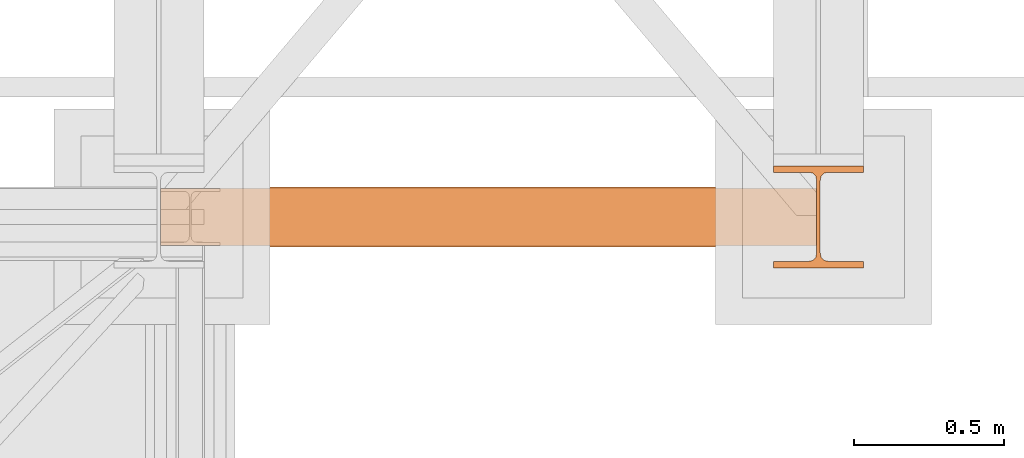
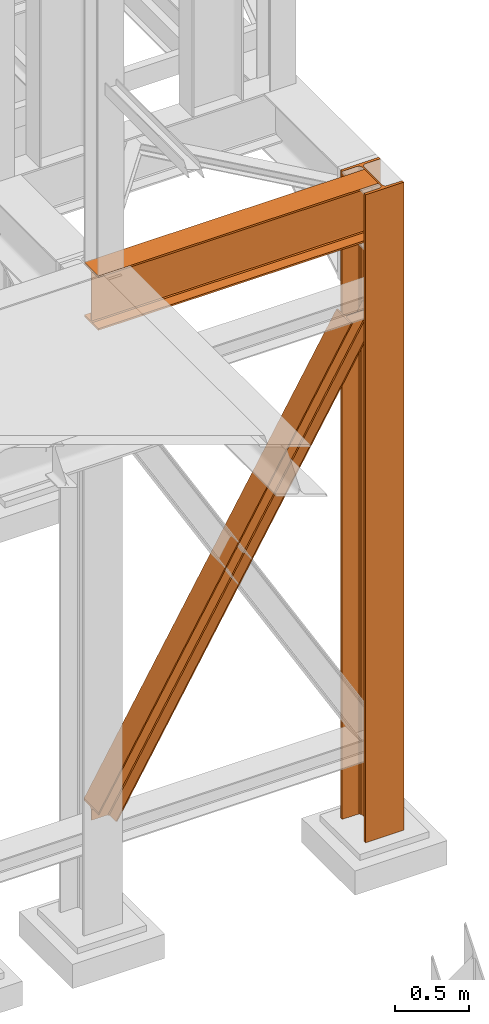
# One storey, part 81 of 208: 3 proxies.
"""IFC2X3 building model written with IfcOpenShell, lengths in millimetres."""

from ifc_helpers import new_model, entity, si_unit, converted_unit, frame, origin, origin_with_axes, place, context, subcontext, project, spatial, faceted_brep, material, element, save


model = new_model("IFC2X3")

# Units and contexts
model_context = context("Model", 3, precision=1e-05, world=origin())
plan_context = context("Plan", 3, precision=1e-05, world=origin())
body_context = subcontext(model_context, "Body", "Model", "MODEL_VIEW")
ifc_project = project(units=[si_unit("LENGTHUNIT", "METRE", prefix="MILLI"), converted_unit("PLANEANGLEUNIT", "DEGREE", entity("IfcPlaneAngleMeasure", 0.0174532925199433), si_unit("PLANEANGLEUNIT", "RADIAN"), dimensions=[0, 0, 0, 0, 0, 0, 0]), si_unit("AREAUNIT", "SQUARE_METRE"), si_unit("VOLUMEUNIT", "CUBIC_METRE")], contexts=[model_context, plan_context])

# Building, storey
building_placement = place(None, origin())
building = spatial("IfcBuilding", under=ifc_project, at=building_placement, CompositionType="COMPLEX")
storey_placement = place(building_placement, origin_with_axes())
storey = spatial("IfcBuildingStorey", under=building, at=storey_placement, Name="Geschoss", CompositionType="ELEMENT")

# Proxies
ifc_material = material(Name="35/80cm")
proxy_1_placement = place(storey_placement, frame((8643.254962568202, -17432.57439531565, -65.01000000000022), z_axis=(0.0, 0.0, 1.0), x_axis=(1.0, 0.0, 0.0)))
element("IfcBuildingElementProxy", 1, at=proxy_1_placement, inside=storey, material=ifc_material, context=body_context, shape_type="Brep", body=[
    faceted_brep([(300.0100119209292, 0.00999999999839929, 0.01000000000027512), (300.0100119209292, 21.51000631809075, 0.01000000000027512), (183.0100057816508, 21.51000631809075, 0.01000000000027512), (169.036290997863, 24.30682016372521, 0.01000000000027512), (158.8068282401564, 34.5362885093673, 0.01000000000027512), (156.0100060126188, 48.51000143050987, 0.01000000000027512), (156.0100060126188, 291.509994695185, 0.01000000000027512), (158.8068282401564, 305.4837150669082, 0.01000000000027512), (169.036290997863, 315.7131685113891, 0.01000000000027512), (183.0100057816508, 318.5099972581847, 0.01000000000027512), (300.0100119209292, 318.5099972581847, 0.01000000000027512), (300.0100119209292, 340.0100035762771, 0.01000000000027512), (0.01000000000021828, 340.0100035762771, 0.01000000000027512), (0.01000000000021828, 318.5099972581847, 0.01000000000027512), (117.0100061392786, 318.5099972581847, 0.01000000000027512), (130.9837209230664, 315.7131685113891, 0.01000000000027512), (141.213183680773, 305.4837150669082, 0.01000000000027512), (144.0100059083106, 291.509994695185, 0.01000000000027512), (144.0100059083106, 48.51000143050987, 0.01000000000027512), (141.213183680773, 34.5362885093673, 0.01000000000027512), (130.9837209230664, 24.30682016372521, 0.01000000000027512), (117.0100061392786, 21.51000631809075, 0.01000000000027512), (0.01000000000021828, 21.51000631809075, 0.01000000000027512), (0.01000000000021828, 0.00999999999839929, 0.01000000000027512), (300.0100119209292, 21.51000631809075, 5350.010005364416), (300.0100119209292, 0.00999999999839929, 5350.010005364416), (0.01000000000021828, 0.00999999999839929, 5350.010005364416), (0.01000000000021828, 21.51000631809075, 5350.010005364416), (117.0100061392786, 21.51000631809075, 5350.010005364416), (130.9837209230664, 24.30682016372521, 5350.010005364416), (141.213183680773, 34.5362885093673, 5350.010005364416), (144.0100059083106, 48.51000143050987, 5350.010005364416), (144.0100059083106, 291.509994695185, 5350.010005364416), (141.213183680773, 305.4837150669082, 5350.010005364416), (130.9837209230664, 315.7131685113891, 5350.010005364416), (117.0100061392786, 318.5099972581847, 5350.010005364416), (0.01000000000021828, 318.5099972581847, 5350.010005364416), (0.01000000000021828, 340.0100035762771, 5350.010005364416), (300.0100119209292, 340.0100035762771, 5350.010005364416), (300.0100119209292, 318.5099972581847, 5350.010005364416), (183.0100057816508, 318.5099972581847, 5350.010005364416), (169.036290997863, 315.7131685113891, 5350.010005364416), (158.8068282401564, 305.4837150669082, 5350.010005364416), (156.0100060126188, 291.509994695185, 5350.010005364416), (156.0100060126188, 48.51000143050987, 5350.010005364416), (158.8068282401564, 34.5362885093673, 5350.010005364416), (169.036290997863, 24.30682016372521, 5350.010005364416), (183.0100057816508, 21.51000631809075, 5350.010005364416), (300.0100119209292, 21.51000631809075, 0.01000000000027512), (300.0100119209292, 0.00999999999839929, 0.01000000000027512), (300.0100119209292, 0.00999999999839929, 5350.010005364416), (300.0100119209292, 21.51000631809075, 5350.010005364416), (183.0100057816508, 21.51000631809075, 0.01000000000027512), (300.0100119209292, 21.51000631809075, 0.01000000000027512), (300.0100119209292, 21.51000631809075, 5350.010005364416), (183.0100057816508, 21.51000631809075, 5350.010005364416), (169.036290997863, 24.30682016372521, 0.01000000000027512), (183.0100057816508, 21.51000631809075, 0.01000000000027512), (183.0100057816508, 21.51000631809075, 5350.010005364416), (169.036290997863, 24.30682016372521, 5350.010005364416), (158.8068282401564, 34.5362885093673, 0.01000000000027512), (169.036290997863, 24.30682016372521, 0.01000000000027512), (169.036290997863, 24.30682016372521, 5350.010005364416), (158.8068282401564, 34.5362885093673, 5350.010005364416), (156.0100060126188, 48.51000143050987, 0.01000000000027512), (158.8068282401564, 34.5362885093673, 0.01000000000027512), (158.8068282401564, 34.5362885093673, 5350.010005364416), (156.0100060126188, 48.51000143050987, 5350.010005364416), (156.0100060126188, 291.509994695185, 0.01000000000027512), (156.0100060126188, 48.51000143050987, 0.01000000000027512), (156.0100060126188, 48.51000143050987, 5350.010005364416), (156.0100060126188, 291.509994695185, 5350.010005364416), (158.8068282401564, 305.4837150669082, 0.01000000000027512), (156.0100060126188, 291.509994695185, 0.01000000000027512), (156.0100060126188, 291.509994695185, 5350.010005364416), (158.8068282401564, 305.4837150669082, 5350.010005364416), (169.036290997863, 315.7131685113891, 0.01000000000027512), (158.8068282401564, 305.4837150669082, 0.01000000000027512), (158.8068282401564, 305.4837150669082, 5350.010005364416), (169.036290997863, 315.7131685113891, 5350.010005364416), (183.0100057816508, 318.5099972581847, 0.01000000000027512), (169.036290997863, 315.7131685113891, 0.01000000000027512), (169.036290997863, 315.7131685113891, 5350.010005364416), (183.0100057816508, 318.5099972581847, 5350.010005364416), (300.0100119209292, 318.5099972581847, 0.01000000000027512), (183.0100057816508, 318.5099972581847, 0.01000000000027512), (183.0100057816508, 318.5099972581847, 5350.010005364416), (300.0100119209292, 318.5099972581847, 5350.010005364416), (300.0100119209292, 340.0100035762771, 0.01000000000027512), (300.0100119209292, 318.5099972581847, 0.01000000000027512), (300.0100119209292, 318.5099972581847, 5350.010005364416), (300.0100119209292, 340.0100035762771, 5350.010005364416), (0.01000000000021828, 340.0100035762771, 0.01000000000027512), (300.0100119209292, 340.0100035762771, 0.01000000000027512), (300.0100119209292, 340.0100035762771, 5350.010005364416), (0.01000000000021828, 340.0100035762771, 5350.010005364416), (0.01000000000021828, 318.5099972581847, 0.01000000000027512), (0.01000000000021828, 340.0100035762771, 0.01000000000027512), (0.01000000000021828, 340.0100035762771, 5350.010005364416), (0.01000000000021828, 318.5099972581847, 5350.010005364416), (117.0100061392786, 318.5099972581847, 0.01000000000027512), (0.01000000000021828, 318.5099972581847, 0.01000000000027512), (0.01000000000021828, 318.5099972581847, 5350.010005364416), (117.0100061392786, 318.5099972581847, 5350.010005364416), (130.9837209230664, 315.7131685113891, 0.01000000000027512), (117.0100061392786, 318.5099972581847, 0.01000000000027512), (117.0100061392786, 318.5099972581847, 5350.010005364416), (130.9837209230664, 315.7131685113891, 5350.010005364416), (141.213183680773, 305.4837150669082, 0.01000000000027512), (130.9837209230664, 315.7131685113891, 0.01000000000027512), (130.9837209230664, 315.7131685113891, 5350.010005364416), (141.213183680773, 305.4837150669082, 5350.010005364416), (144.0100059083106, 291.509994695185, 0.01000000000027512), (141.213183680773, 305.4837150669082, 0.01000000000027512), (141.213183680773, 305.4837150669082, 5350.010005364416), (144.0100059083106, 291.509994695185, 5350.010005364416), (144.0100059083106, 48.51000143050987, 0.01000000000027512), (144.0100059083106, 291.509994695185, 0.01000000000027512), (144.0100059083106, 291.509994695185, 5350.010005364416), (144.0100059083106, 48.51000143050987, 5350.010005364416), (141.213183680773, 34.5362885093673, 0.01000000000027512), (144.0100059083106, 48.51000143050987, 0.01000000000027512), (144.0100059083106, 48.51000143050987, 5350.010005364416), (141.213183680773, 34.5362885093673, 5350.010005364416), (130.9837209230664, 24.30682016372521, 0.01000000000027512), (141.213183680773, 34.5362885093673, 0.01000000000027512), (141.213183680773, 34.5362885093673, 5350.010005364416), (130.9837209230664, 24.30682016372521, 5350.010005364416), (117.0100061392786, 21.51000631809075, 0.01000000000027512), (130.9837209230664, 24.30682016372521, 0.01000000000027512), (130.9837209230664, 24.30682016372521, 5350.010005364416), (117.0100061392786, 21.51000631809075, 5350.010005364416), (0.01000000000021828, 21.51000631809075, 0.01000000000027512), (117.0100061392786, 21.51000631809075, 0.01000000000027512), (117.0100061392786, 21.51000631809075, 5350.010005364416), (0.01000000000021828, 21.51000631809075, 5350.010005364416), (0.01000000000021828, 0.00999999999839929, 0.01000000000027512), (0.01000000000021828, 21.51000631809075, 0.01000000000027512), (0.01000000000021828, 21.51000631809075, 5350.010005364416), (0.01000000000021828, 0.00999999999839929, 5350.010005364416), (300.0100119209292, 0.00999999999839929, 0.01000000000027512), (0.01000000000021828, 0.00999999999839929, 0.01000000000027512), (0.01000000000021828, 0.00999999999839929, 5350.010005364416), (300.0100119209292, 0.00999999999839929, 5350.010005364416)], [[[0, 1, 2, 3, 4, 5, 6, 7, 8, 9, 10, 11, 12, 13, 14, 15, 16, 17, 18, 19, 20, 21, 22, 23]], [[24, 25, 26, 27, 28, 29, 30, 31, 32, 33, 34, 35, 36, 37, 38, 39, 40, 41, 42, 43, 44, 45, 46, 47]], [[48, 49, 50, 51]], [[52, 53, 54, 55]], [[56, 57, 58, 59]], [[60, 61, 62, 63]], [[64, 65, 66, 67]], [[68, 69, 70, 71]], [[72, 73, 74, 75]], [[76, 77, 78, 79]], [[80, 81, 82, 83]], [[84, 85, 86, 87]], [[88, 89, 90, 91]], [[92, 93, 94, 95]], [[96, 97, 98, 99]], [[100, 101, 102, 103]], [[104, 105, 106, 107]], [[108, 109, 110, 111]], [[112, 113, 114, 115]], [[116, 117, 118, 119]], [[120, 121, 122, 123]], [[124, 125, 126, 127]], [[128, 129, 130, 131]], [[132, 133, 134, 135]], [[136, 137, 138, 139]], [[140, 141, 142, 143]]], orient=[[False], [False], [False], [False], [False], [False], [False], [False], [False], [False], [False], [False], [False], [False], [False], [False], [False], [False], [False], [False], [False], [False], [False], [False], [False], [False]]),
])
proxy_2_placement = place(storey_placement, frame((6600.004889571828, -17362.5323246858, 734.9900149335328), z_axis=(0.0, 0.0, 1.0), x_axis=(1.0, 0.0, 0.0)))
element("IfcBuildingElementProxy", 2, at=proxy_2_placement, inside=storey, context=body_context, shape_type="Brep", body=[
    faceted_brep([(0.01008502161312208, 0.00999999999839929, 120.8497915510925), (0.01008502161312208, 200.0100029802306, 120.8497915510925), (1970.595410063093, 200.0100029802306, 3468.009977913908), (1970.595410063093, 0.00999999999839929, 3468.009977913908), (0.01008502161312208, 200.0100029802306, 120.8497915510925), (0.01008502161312208, 200.0100029802306, 101.4682129393399), (1982.007890767009, 200.0100029802306, 3468.009977913908), (1970.595410063093, 200.0100029802306, 3468.009977913908), (0.01008502161312208, 200.0100029802306, 101.4682129393399), (0.01008502127388056, 121.2600035762771, 101.4681984983712), (1982.007899269971, 121.2600035762771, 3468.009977913908), (1982.007890767009, 200.0100029802306, 3468.009977913908), (0.01008502127388056, 121.2600035762771, 101.4681984983712), (0.009999999999308784, 111.9441915473326, 97.8542740943027), (1984.135808151257, 111.9441915473326, 3468.009977913909), (1982.007899269971, 121.2600035762771, 3468.009977913908), (0.009999999999308784, 111.9441915473326, 97.8542740943027), (0.01008502161312208, 105.1245498640819, 84.63689245399053), (1991.918714280975, 105.1245498640819, 3468.009977913908), (1984.135808151257, 111.9441915473326, 3468.009977913909), (0.01008502161312208, 105.1245498640819, 84.63689245399053), (0.01008502161312208, 103.2600015571697, 66.58142866151934), (2002.550367938204, 103.2600015571697, 3468.009977913908), (1991.918714280975, 105.1245498640819, 3468.009977913908), (0.01008502161312208, 103.2600015571697, 0.01000000000010459), (113.7187158034394, 103.2600015571697, 0.01000000000033197), (2155.477653586077, 103.2600015571697, 3468.009977913908), (2002.550367938204, 103.2600015571697, 3468.009977913908), (0.01008502161312208, 103.2600015571697, 66.58142866151934), (113.7187158034394, 103.2600015571697, 0.01000000000033197), (124.3486060538462, 105.1245498640819, 0.01000000000021828), (2166.109307243305, 105.1245498640819, 3468.009977913908), (2155.477653586077, 103.2600015571697, 3468.009977913908), (124.3486060538462, 105.1245498640819, 0.01000000000021828), (132.1302232850376, 111.9441915473326, 0.009999999999877218), (2173.892213373023, 111.9441915473326, 3468.009977913908), (2166.109307243305, 105.1245498640819, 3468.009977913908), (132.1302232850376, 111.9441915473326, 0.009999999999877218), (134.2577800655363, 121.2600035762771, 0.009999999999877218), (2176.020122254309, 121.2600035762771, 3468.009977913907), (2173.892213373023, 111.9441915473326, 3468.009977913908), (134.2577800655363, 121.2600035762771, 0.009999999999877218), (134.2577800655363, 200.0100029802306, 0.009999999999877218), (2176.020122254309, 200.0100029802306, 3468.009977913907), (2176.020122254309, 121.2600035762771, 3468.009977913907), (134.2577800655363, 200.0100029802306, 0.009999999999877218), (145.6683745225655, 200.0100029802306, 0.01000000000010459), (2187.432602958224, 200.0100029802306, 3468.009977913908), (2176.020122254309, 200.0100029802306, 3468.009977913907), (145.6683745225655, 200.0100029802306, 0.01000000000010459), (145.6683745225655, 0.00999999999839929, 0.01000000000010459), (2187.432602958224, 0.00999999999839929, 3468.009977913908), (2187.432602958224, 200.0100029802306, 3468.009977913908), (145.6683745225655, 0.00999999999839929, 0.01000000000010459), (134.2577800655363, 0.00999999999839929, 0.009999999999990905), (2176.020122254307, 0.00999999999839929, 3468.009977913908), (2187.432602958224, 0.00999999999839929, 3468.009977913908), (134.2577800655363, 0.00999999999839929, 0.009999999999990905), (134.2577800655363, 78.75999940395195, 0.009999999999877218), (2176.020122254309, 78.75999940395195, 3468.009977913907), (2176.020122254307, 0.00999999999839929, 3468.009977913908), (134.2577800655363, 78.75999940395195, 0.009999999999877218), (132.1302232850376, 88.07581143289644, 0.009999999999877218), (2173.892213373023, 88.07581143290008, 3468.009977913908), (2176.020122254309, 78.75999940395195, 3468.009977913907), (132.1302232850376, 88.07581143289644, 0.009999999999877218), (124.3486060538453, 94.89545311614711, 0.009999999999877218), (2166.109307243305, 94.89545311614711, 3468.009977913908), (2173.892213373023, 88.07581143290008, 3468.009977913908), (124.3486060538453, 94.89545311614711, 0.009999999999877218), (113.7187158034394, 96.7600014230593, 0.01000000000033197), (2155.477653586077, 96.7600014230593, 3468.009977913908), (2166.109307243305, 94.89545311614711, 3468.009977913908), (113.7187158034394, 96.7600014230593, 0.01000000000033197), (0.01008502161312208, 96.7600014230593, 0.01000000000010459), (0.01008502161312208, 96.7600014230593, 66.581428661519), (2002.550367938204, 96.7600014230593, 3468.009977913908), (2155.477653586077, 96.7600014230593, 3468.009977913908), (0.01008502161312208, 96.7600014230593, 66.581428661519), (0.01008502161312208, 94.89545311615075, 84.63689245399053), (1991.918714280975, 94.89545311614711, 3468.009977913908), (2002.550367938204, 96.7600014230593, 3468.009977913908), (0.01008502161312208, 94.89545311615075, 84.63689245399053), (0.01008502161312208, 88.07581143289644, 97.85441850857103), (1984.135808151257, 88.07581143289644, 3468.009977913909), (1991.918714280975, 94.89545311614711, 3468.009977913908), (0.01008502161312208, 88.07581143289644, 97.85441850857103), (0.01016988588980894, 78.75999940395195, 101.4683426459952), (1982.007899269971, 78.75999940395195, 3468.009977913908), (1984.135808151257, 88.07581143289644, 3468.009977913909), (0.01016988588980894, 78.75999940395195, 101.4683426459952), (0.0100850219523636, 0.00999999999839929, 101.4682129399165), (1982.007890767009, 0.00999999999839929, 3468.009977913908), (1982.007899269971, 78.75999940395195, 3468.009977913908), (0.0100850219523636, 0.00999999999839929, 101.4682129399165), (0.01008502161312208, 0.00999999999839929, 120.8497915510925), (1970.595410063093, 0.00999999999839929, 3468.009977913908), (1982.007890767009, 0.00999999999839929, 3468.009977913908), (1970.595410063093, 0.00999999999839929, 3468.009977913908), (1970.595410063093, 200.0100029802306, 3468.009977913908), (1982.007890767009, 200.0100029802306, 3468.009977913908), (1982.007899269971, 121.2600035762771, 3468.009977913908), (1984.135808151257, 111.9441915473326, 3468.009977913909), (1991.918714280975, 105.1245498640819, 3468.009977913908), (2002.550367938204, 103.2600015571697, 3468.009977913908), (2155.477653586077, 103.2600015571697, 3468.009977913908), (2166.109307243305, 105.1245498640819, 3468.009977913908), (2173.892213373023, 111.9441915473326, 3468.009977913908), (2176.020122254309, 121.2600035762771, 3468.009977913907), (2176.020122254309, 200.0100029802306, 3468.009977913907), (2187.432602958224, 200.0100029802306, 3468.009977913908), (2187.432602958224, 0.00999999999839929, 3468.009977913908), (2176.020122254307, 0.00999999999839929, 3468.009977913908), (2176.020122254309, 78.75999940395195, 3468.009977913907), (2173.892213373023, 88.07581143290008, 3468.009977913908), (2166.109307243305, 94.89545311614711, 3468.009977913908), (2155.477653586077, 96.7600014230593, 3468.009977913908), (2002.550367938204, 96.7600014230593, 3468.009977913908), (1991.918714280975, 94.89545311614711, 3468.009977913908), (1984.135808151257, 88.07581143289644, 3468.009977913909), (1982.007899269971, 78.75999940395195, 3468.009977913908), (1982.007890767009, 0.00999999999839929, 3468.009977913908), (0.01008502161312208, 96.7600014230593, 0.01000000000010459), (0.01008502161312208, 103.2600015571697, 0.01000000000010459), (0.01008502161312208, 103.2600015571697, 66.58142866151934), (0.01008502161312208, 105.1245498640819, 84.63689245399053), (0.009999999999308784, 111.9441915473326, 97.8542740943027), (0.01008502127388056, 121.2600035762771, 101.4681984983712), (0.01008502161312208, 200.0100029802306, 101.4682129393399), (0.01008502161312208, 200.0100029802306, 120.8497915510925), (0.01008502161312208, 0.00999999999839929, 120.8497915510925), (0.0100850219523636, 0.00999999999839929, 101.4682129399165), (0.01016988588980894, 78.75999940395195, 101.4683426459952), (0.01008502161312208, 88.07581143289644, 97.85441850857103), (0.01008502161312208, 94.89545311615075, 84.63689245399053), (0.01008502161312208, 96.7600014230593, 66.581428661519), (113.7187158034394, 103.2600015571697, 0.01000000000033197), (0.01008502161312208, 103.2600015571697, 0.01000000000010459), (0.01008502161312208, 96.7600014230593, 0.01000000000010459), (113.7187158034394, 96.7600014230593, 0.01000000000033197), (124.3486060538453, 94.89545311614711, 0.009999999999877218), (132.1302232850376, 88.07581143289644, 0.009999999999877218), (134.2577800655363, 78.75999940395195, 0.009999999999877218), (134.2577800655363, 0.00999999999839929, 0.009999999999990905), (145.6683745225655, 0.00999999999839929, 0.01000000000010459), (145.6683745225655, 200.0100029802306, 0.01000000000010459), (134.2577800655363, 200.0100029802306, 0.009999999999877218), (134.2577800655363, 121.2600035762771, 0.009999999999877218), (132.1302232850376, 111.9441915473326, 0.009999999999877218), (124.3486060538462, 105.1245498640819, 0.01000000000021828)], [[[0, 1, 2, 3]], [[4, 5, 6, 7]], [[8, 9, 10, 11]], [[12, 13, 14, 15]], [[16, 17, 18, 19]], [[20, 21, 22, 23]], [[24, 25, 26, 27, 28]], [[29, 30, 31, 32]], [[33, 34, 35, 36]], [[37, 38, 39, 40]], [[41, 42, 43, 44]], [[45, 46, 47, 48]], [[49, 50, 51, 52]], [[53, 54, 55, 56]], [[57, 58, 59, 60]], [[61, 62, 63, 64]], [[65, 66, 67, 68]], [[69, 70, 71, 72]], [[73, 74, 75, 76, 77]], [[78, 79, 80, 81]], [[82, 83, 84, 85]], [[86, 87, 88, 89]], [[90, 91, 92, 93]], [[94, 95, 96, 97]], [[98, 99, 100, 101, 102, 103, 104, 105, 106, 107, 108, 109, 110, 111, 112, 113, 114, 115, 116, 117, 118, 119, 120, 121]], [[122, 123, 124, 125, 126, 127, 128, 129, 130, 131, 132, 133, 134, 135]], [[136, 137, 138, 139, 140, 141, 142, 143, 144, 145, 146, 147, 148, 149]]], orient=[[False], [False], [False], [False], [False], [False], [False], [False], [False], [False], [False], [False], [False], [False], [False], [False], [False], [False], [False], [False], [False], [False], [False], [False], [False], [False], [False]]),
])
proxy_3_placement = place(storey_placement, frame((6599.254968580832, -17357.574399786, 4834.989987483023), z_axis=(0.0, 0.0, 1.0), x_axis=(1.0, 0.0, 0.0)))
element("IfcBuildingElementProxy", 3, at=proxy_3_placement, inside=storey, context=body_context, shape_type="Brep", body=[
    faceted_brep([(2188.009999895692, 0.00999999999839929, 450.0100178813937), (2188.009999895692, 190.0100125169738, 450.0100178813937), (2188.009999895692, 190.0100125169738, 435.4100240564349), (2188.009999895692, 120.7100073045476, 435.4100091552737), (2188.009999895692, 109.8415622657522, 433.2347078418734), (2188.009999895692, 101.8853126263603, 425.2784563398363), (2188.009999895692, 99.71000619068582, 414.4100113010409), (2188.009999895692, 99.71000619068582, 35.60999167919181), (2188.009999895692, 101.8853126263603, 24.74154664039634), (2188.009999895692, 109.8415622657522, 16.78529513835929), (2188.009999895692, 120.7100073045476, 14.60999382495902), (2188.009999895692, 190.0100125169738, 14.60999382495902), (2188.009999895692, 190.0100125169738, 0.01000000000021828), (2188.009999895692, 0.00999999999839929, 0.01000000000021828), (2188.009999895692, 0.00999999999839929, 14.60999382495902), (2188.009999895692, 69.31000521242458, 14.60999382495902), (2188.009999895692, 80.17845025122006, 16.78529513835929), (2188.009999895692, 88.13469989061196, 24.74154664039634), (2188.009999895692, 90.31000632628638, 35.60999167919181), (2188.009999895692, 90.31000632628638, 414.4100113010409), (2188.009999895692, 88.13469989061196, 425.2784563398363), (2188.009999895692, 80.17845025122006, 433.2347078418734), (2188.009999895692, 69.31000521242458, 435.4100091552737), (2188.009999895692, 0.00999999999839929, 435.4100240564349), (2188.009999895692, 190.0100125169738, 450.0100178813937), (2188.009999895692, 0.00999999999839929, 450.0100178813937), (0.01000000000021828, 0.00999999999839929, 450.0100178813937), (0.01000000000021828, 190.0100125169738, 450.0100178813937), (2188.009999895692, 190.0100125169738, 435.4100240564349), (2188.009999895692, 190.0100125169738, 450.0100178813937), (0.01000000000021828, 190.0100125169738, 450.0100178813937), (0.01000000000021828, 190.0100125169738, 435.4100240564349), (2188.009999895692, 120.7100073045476, 435.4100091552737), (2188.009999895692, 190.0100125169738, 435.4100240564349), (0.01000000000021828, 190.0100125169738, 435.4100240564349), (0.01000000000021828, 120.7100073045476, 435.4100091552737), (2188.009999895692, 109.8415622657522, 433.2347078418734), (2188.009999895692, 120.7100073045476, 435.4100091552737), (0.01000000000021828, 120.7100073045476, 435.4100091552737), (0.01000000000021828, 109.8415622657522, 433.2347078418734), (2188.009999895692, 101.8853126263603, 425.2784563398363), (2188.009999895692, 109.8415622657522, 433.2347078418734), (0.01000000000021828, 109.8415622657522, 433.2347078418734), (0.01000000000021828, 101.8853126263603, 425.2784563398363), (2188.009999895692, 99.71000619068582, 414.4100113010409), (2188.009999895692, 101.8853126263603, 425.2784563398363), (0.01000000000021828, 101.8853126263603, 425.2784563398363), (0.01000000000021828, 99.71000619068582, 414.4100113010409), (2188.009999895692, 99.71000619068582, 35.60999167919181), (2188.009999895692, 99.71000619068582, 414.4100113010409), (0.01000000000021828, 99.71000619068582, 414.4100113010409), (0.01000000000021828, 99.71000619068582, 35.60999167919181), (2188.009999895692, 101.8853126263603, 24.74154664039634), (2188.009999895692, 99.71000619068582, 35.60999167919181), (0.01000000000021828, 99.71000619068582, 35.60999167919181), (0.01000000000021828, 101.8853126263603, 24.74154664039634), (2188.009999895692, 109.8415622657522, 16.78529513835929), (2188.009999895692, 101.8853126263603, 24.74154664039634), (0.01000000000021828, 101.8853126263603, 24.74154664039634), (0.01000000000021828, 109.8415622657522, 16.78529513835929), (2188.009999895692, 120.7100073045476, 14.60999382495902), (2188.009999895692, 109.8415622657522, 16.78529513835929), (0.01000000000021828, 109.8415622657522, 16.78529513835929), (0.01000000000021828, 120.7100073045476, 14.60999382495902), (2188.009999895692, 190.0100125169738, 14.60999382495902), (2188.009999895692, 120.7100073045476, 14.60999382495902), (0.01000000000021828, 120.7100073045476, 14.60999382495902), (0.01000000000021828, 190.0100125169738, 14.60999382495902), (2188.009999895692, 190.0100125169738, 0.01000000000021828), (2188.009999895692, 190.0100125169738, 14.60999382495902), (0.01000000000021828, 190.0100125169738, 14.60999382495902), (0.01000000000021828, 190.0100125169738, 0.01000000000021828), (2188.009999895692, 0.00999999999839929, 0.01000000000021828), (2188.009999895692, 190.0100125169738, 0.01000000000021828), (0.01000000000021828, 190.0100125169738, 0.01000000000021828), (0.01000000000021828, 0.00999999999839929, 0.01000000000021828), (2188.009999895692, 0.00999999999839929, 14.60999382495902), (2188.009999895692, 0.00999999999839929, 0.01000000000021828), (0.01000000000021828, 0.00999999999839929, 0.01000000000021828), (0.01000000000021828, 0.00999999999839929, 14.60999382495902), (2188.009999895692, 69.31000521242458, 14.60999382495902), (2188.009999895692, 0.00999999999839929, 14.60999382495902), (0.01000000000021828, 0.00999999999839929, 14.60999382495902), (0.01000000000021828, 69.31000521242458, 14.60999382495902), (2188.009999895692, 80.17845025122006, 16.78529513835929), (2188.009999895692, 69.31000521242458, 14.60999382495902), (0.01000000000021828, 69.31000521242458, 14.60999382495902), (0.01000000000021828, 80.17845025122006, 16.78529513835929), (2188.009999895692, 88.13469989061196, 24.74154664039634), (2188.009999895692, 80.17845025122006, 16.78529513835929), (0.01000000000021828, 80.17845025122006, 16.78529513835929), (0.01000000000021828, 88.13469989061196, 24.74154664039634), (2188.009999895692, 90.31000632628638, 35.60999167919181), (2188.009999895692, 88.13469989061196, 24.74154664039634), (0.01000000000021828, 88.13469989061196, 24.74154664039634), (0.01000000000021828, 90.31000632628638, 35.60999167919181), (2188.009999895692, 90.31000632628638, 414.4100113010409), (2188.009999895692, 90.31000632628638, 35.60999167919181), (0.01000000000021828, 90.31000632628638, 35.60999167919181), (0.01000000000021828, 90.31000632628638, 414.4100113010409), (2188.009999895692, 88.13469989061196, 425.2784563398363), (2188.009999895692, 90.31000632628638, 414.4100113010409), (0.01000000000021828, 90.31000632628638, 414.4100113010409), (0.01000000000021828, 88.13469989061196, 425.2784563398363), (2188.009999895692, 80.17845025122006, 433.2347078418734), (2188.009999895692, 88.13469989061196, 425.2784563398363), (0.01000000000021828, 88.13469989061196, 425.2784563398363), (0.01000000000021828, 80.17845025122006, 433.2347078418734), (2188.009999895692, 69.31000521242458, 435.4100091552737), (2188.009999895692, 80.17845025122006, 433.2347078418734), (0.01000000000021828, 80.17845025122006, 433.2347078418734), (0.01000000000021828, 69.31000521242458, 435.4100091552737), (2188.009999895692, 0.00999999999839929, 435.4100240564349), (2188.009999895692, 69.31000521242458, 435.4100091552737), (0.01000000000021828, 69.31000521242458, 435.4100091552737), (0.01000000000021828, 0.00999999999839929, 435.4100240564349), (2188.009999895692, 0.00999999999839929, 450.0100178813937), (2188.009999895692, 0.00999999999839929, 435.4100240564349), (0.01000000000021828, 0.00999999999839929, 435.4100240564349), (0.01000000000021828, 0.00999999999839929, 450.0100178813937), (0.01000000000021828, 0.00999999999839929, 450.0100178813937), (0.01000000000021828, 0.00999999999839929, 435.4100240564349), (0.01000000000021828, 69.31000521242458, 435.4100091552737), (0.01000000000021828, 80.17845025122006, 433.2347078418734), (0.01000000000021828, 88.13469989061196, 425.2784563398363), (0.01000000000021828, 90.31000632628638, 414.4100113010409), (0.01000000000021828, 90.31000632628638, 35.60999167919181), (0.01000000000021828, 88.13469989061196, 24.74154664039634), (0.01000000000021828, 80.17845025122006, 16.78529513835929), (0.01000000000021828, 69.31000521242458, 14.60999382495902), (0.01000000000021828, 0.00999999999839929, 14.60999382495902), (0.01000000000021828, 0.00999999999839929, 0.01000000000021828), (0.01000000000021828, 190.0100125169738, 0.01000000000021828), (0.01000000000021828, 190.0100125169738, 14.60999382495902), (0.01000000000021828, 120.7100073045476, 14.60999382495902), (0.01000000000021828, 109.8415622657522, 16.78529513835929), (0.01000000000021828, 101.8853126263603, 24.74154664039634), (0.01000000000021828, 99.71000619068582, 35.60999167919181), (0.01000000000021828, 99.71000619068582, 414.4100113010409), (0.01000000000021828, 101.8853126263603, 425.2784563398363), (0.01000000000021828, 109.8415622657522, 433.2347078418734), (0.01000000000021828, 120.7100073045476, 435.4100091552737), (0.01000000000021828, 190.0100125169738, 435.4100240564349), (0.01000000000021828, 190.0100125169738, 450.0100178813937)], [[[0, 1, 2, 3, 4, 5, 6, 7, 8, 9, 10, 11, 12, 13, 14, 15, 16, 17, 18, 19, 20, 21, 22, 23]], [[24, 25, 26, 27]], [[28, 29, 30, 31]], [[32, 33, 34, 35]], [[36, 37, 38, 39]], [[40, 41, 42, 43]], [[44, 45, 46, 47]], [[48, 49, 50, 51]], [[52, 53, 54, 55]], [[56, 57, 58, 59]], [[60, 61, 62, 63]], [[64, 65, 66, 67]], [[68, 69, 70, 71]], [[72, 73, 74, 75]], [[76, 77, 78, 79]], [[80, 81, 82, 83]], [[84, 85, 86, 87]], [[88, 89, 90, 91]], [[92, 93, 94, 95]], [[96, 97, 98, 99]], [[100, 101, 102, 103]], [[104, 105, 106, 107]], [[108, 109, 110, 111]], [[112, 113, 114, 115]], [[116, 117, 118, 119]], [[120, 121, 122, 123, 124, 125, 126, 127, 128, 129, 130, 131, 132, 133, 134, 135, 136, 137, 138, 139, 140, 141, 142, 143]]], orient=[[False], [False], [False], [False], [False], [False], [False], [False], [False], [False], [False], [False], [False], [False], [False], [False], [False], [False], [False], [False], [False], [False], [False], [False], [False], [False]]),
])

save(model, "model.ifc")
